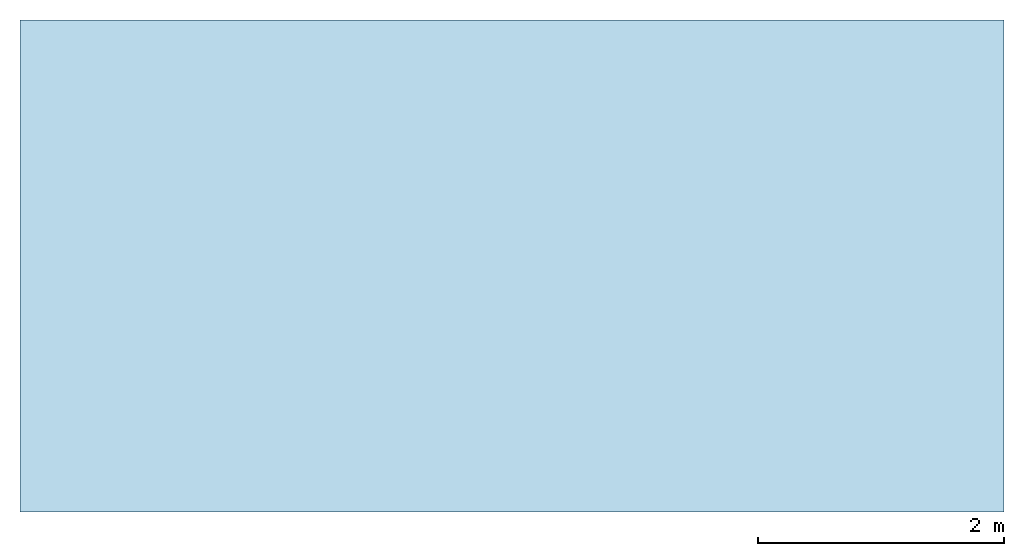
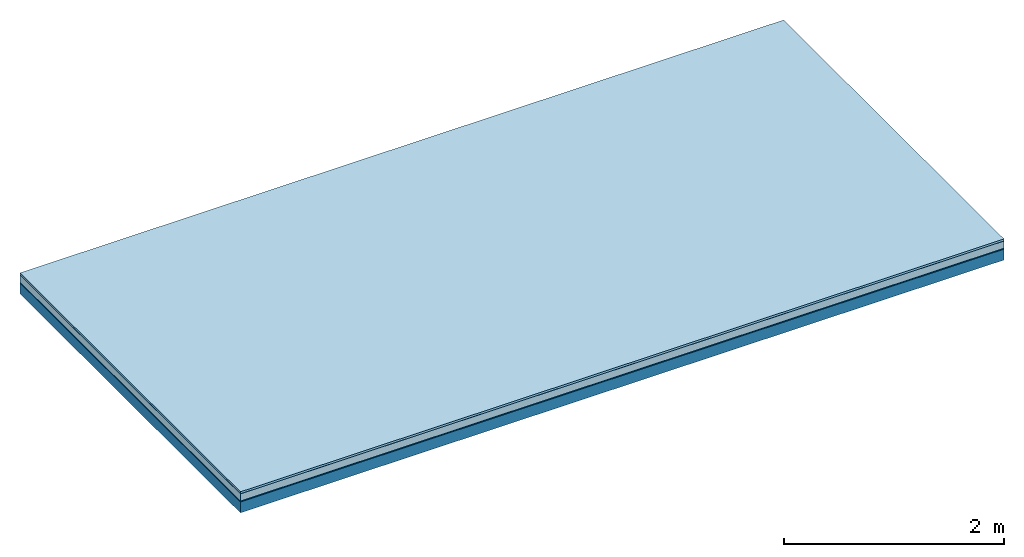
# One storey: 5 plates, 1 member, 1 element without a shape of its own.
"""IFC4 building model written with IfcOpenShell, lengths in metres."""

from ifc_helpers import new_model, si_unit, derived_unit, direction, frame, frame_2d, origin, origin_with_axes, place, context, project, spatial, rectangle, extrude, material, layer, layer_set, type_object, element, aggregate, save


model = new_model("IFC4")

# Units and contexts
plan_context = context("Plan", 3, precision=1e-05, world=origin(), true_north=direction((0.0, 1.0)))
model_context = context("Model", 3, precision=1e-05, world=origin(), true_north=direction((0.0, 1.0)))
ifc_project = project(units=[si_unit("LENGTHUNIT", "METRE"), derived_unit("SOUNDPRESSUREUNIT", [(si_unit("PRESSUREUNIT", "PASCAL", prefix="MICRO"), 0)]), si_unit("ENERGYUNIT", "JOULE", prefix="MEGA"), si_unit("MASSUNIT", "GRAM", prefix="KILO"), derived_unit("THERMALTRANSMITTANCEUNIT", [(si_unit("POWERUNIT", "WATT"), 1), (si_unit("AREAUNIT", "SQUARE_METRE"), -1), (si_unit("THERMODYNAMICTEMPERATUREUNIT", "KELVIN"), -1)]), derived_unit("AREADENSITYUNIT", [(si_unit("MASSUNIT", "GRAM", prefix="KILO"), 1), (si_unit("AREAUNIT", "SQUARE_METRE"), -1)]), derived_unit("USERDEFINED", [(si_unit("ENERGYUNIT", "JOULE", prefix="MEGA"), 1), (si_unit("AREAUNIT", "SQUARE_METRE"), -1)])], contexts=[plan_context, model_context])

# Site, building, storey
site = spatial("IfcSite", under=ifc_project)
building_placement = place(None, origin())
building = spatial("IfcBuilding", under=site, at=building_placement)
storey_placement = place(building_placement, origin())
storey = spatial("IfcBuildingStorey", under=building, at=storey_placement)

# Slab, member, plates
ifc_material_1 = material(Name="with tongue and groove", Category="07.009")
ifc_layer_1 = layer(ifc_material_1, 0.022, Name="Flooring")
ifc_material_2 = material(Category="09.006")
ifc_layer_2 = layer(ifc_material_2, 0.0005, Name="layer")
ifc_material_3 = material(Category="07.011")
ifc_layer_3 = layer(ifc_material_3, 0.08, Name="On-material")
ifc_material_4 = material(Name="Wood fiber generic product", Category="10.009")
ifc_layer_4 = layer(ifc_material_4, 0.01, Name="Impact sound insulation")
ifc_material_5 = material(Name="protection", Category="09.007")
ifc_layer_5 = layer(ifc_material_5, 0.0005, Name="Sub-floor")
ifc_material_6 = material(Name="no composite action")
ifc_layer_6 = layer(ifc_material_6, 0.0, Name="Bond")
ifc_layer_7 = layer(None, 0.12, Name="Supporting structure")
ifc_layer_set = layer_set([ifc_layer_1, ifc_layer_2, ifc_layer_3, ifc_layer_4, ifc_layer_5, ifc_layer_6, ifc_layer_7])
slab_type = type_object("IfcSlabType", Name="A2015", PredefinedType="NOTDEFINED", material=ifc_layer_set)
slab_placement = place(None, frame((0.0, 0.0, 0.0), z_axis=(0.0, 0.0, -1.0), x_axis=(1.0, 0.0, 0.0)))
slab = element("IfcSlab", 1, at=slab_placement, inside=storey, type_object=slab_type, material=ifc_layer_set, Name="Slab #1")
ifc_material_7 = material(Name="Solid timber panel")
member_placement = place(slab_placement, origin())
member = element("IfcMember", 2, at=member_placement, material=ifc_material_7, Name="Supporting structure", context=plan_context, shape_type="SweptSolid", body=[
    extrude(rectangle(XDim=1.0, YDim=0.12, at=frame_2d((0.5, 0.06), x_axis=(1.0, 0.0))), frame((0.0, 4.0, 0.113), z_axis=(0.0, -1.0, 0.0), x_axis=(1.0, 0.0, 0.0)), (0.0, 0.0, 1.0), 4.0),
    extrude(rectangle(XDim=1.0, YDim=0.12, at=frame_2d((0.5, 0.06), x_axis=(1.0, 0.0))), frame((1.0, 4.0, 0.113), z_axis=(0.0, -1.0, 0.0), x_axis=(1.0, 0.0, 0.0)), (0.0, 0.0, 1.0), 4.0),
    extrude(rectangle(XDim=1.0, YDim=0.12, at=frame_2d((0.5, 0.06), x_axis=(1.0, 0.0))), frame((2.0, 4.0, 0.113), z_axis=(0.0, -1.0, 0.0), x_axis=(1.0, 0.0, 0.0)), (0.0, 0.0, 1.0), 4.0),
    extrude(rectangle(XDim=1.0, YDim=0.12, at=frame_2d((0.5, 0.06), x_axis=(1.0, 0.0))), frame((3.0, 4.0, 0.113), z_axis=(0.0, -1.0, 0.0), x_axis=(1.0, 0.0, 0.0)), (0.0, 0.0, 1.0), 4.0),
    extrude(rectangle(XDim=1.0, YDim=0.12, at=frame_2d((0.5, 0.06), x_axis=(1.0, 0.0))), frame((4.0, 4.0, 0.113), z_axis=(0.0, -1.0, 0.0), x_axis=(1.0, 0.0, 0.0)), (0.0, 0.0, 1.0), 4.0),
    extrude(rectangle(XDim=1.0, YDim=0.12, at=frame_2d((0.5, 0.06), x_axis=(1.0, 0.0))), frame((5.0, 4.0, 0.113), z_axis=(0.0, -1.0, 0.0), x_axis=(1.0, 0.0, 0.0)), (0.0, 0.0, 1.0), 4.0),
    extrude(rectangle(XDim=1.0, YDim=0.12, at=frame_2d((0.5, 0.06), x_axis=(1.0, 0.0))), frame((6.0, 4.0, 0.113), z_axis=(0.0, -1.0, 0.0), x_axis=(1.0, 0.0, 0.0)), (0.0, 0.0, 1.0), 4.0),
    extrude(rectangle(XDim=1.0, YDim=0.12, at=frame_2d((0.5, 0.06), x_axis=(1.0, 0.0))), frame((7.0, 4.0, 0.113), z_axis=(0.0, -1.0, 0.0), x_axis=(1.0, 0.0, 0.0)), (0.0, 0.0, 1.0), 4.0),
])
plate_1_placement = place(slab_placement, origin())
plate_1 = element("IfcPlate", 3, at=plate_1_placement, material=ifc_material_1, Name="Flooring", context=plan_context, shape_type="SweptSolid", body=[
    extrude(rectangle(XDim=8.0, YDim=4.0, at=frame_2d((4.0, 2.0), x_axis=(1.0, 0.0))), origin_with_axes(), (0.0, 0.0, 1.0), 0.022),
])
plate_2_placement = place(slab_placement, origin())
plate_2 = element("IfcPlate", 4, at=plate_2_placement, material=ifc_material_2, Name="layer", context=plan_context, shape_type="SweptSolid", body=[
    extrude(rectangle(XDim=8.0, YDim=4.0, at=frame_2d((4.0, 2.0), x_axis=(1.0, 0.0))), frame((0.0, 0.0, 0.022), z_axis=(0.0, 0.0, 1.0), x_axis=(1.0, 0.0, 0.0)), (0.0, 0.0, 1.0), 0.0005),
])
plate_3_placement = place(slab_placement, origin())
plate_3 = element("IfcPlate", 5, at=plate_3_placement, material=ifc_material_3, Name="On-material", context=plan_context, shape_type="SweptSolid", body=[
    extrude(rectangle(XDim=8.0, YDim=4.0, at=frame_2d((4.0, 2.0), x_axis=(1.0, 0.0))), frame((0.0, 0.0, 0.0225), z_axis=(0.0, 0.0, 1.0), x_axis=(1.0, 0.0, 0.0)), (0.0, 0.0, 1.0), 0.08),
])
plate_4_placement = place(slab_placement, origin())
plate_4 = element("IfcPlate", 6, at=plate_4_placement, material=ifc_material_4, Name="Impact sound insulation", context=plan_context, shape_type="SweptSolid", body=[
    extrude(rectangle(XDim=8.0, YDim=4.0, at=frame_2d((4.0, 2.0), x_axis=(1.0, 0.0))), frame((0.0, 0.0, 0.1025), z_axis=(0.0, 0.0, 1.0), x_axis=(1.0, 0.0, 0.0)), (0.0, 0.0, 1.0), 0.01),
])
plate_5_placement = place(slab_placement, origin())
plate_5 = element("IfcPlate", 7, at=plate_5_placement, material=ifc_material_5, Name="Sub-floor", context=plan_context, shape_type="SweptSolid", body=[
    extrude(rectangle(XDim=8.0, YDim=4.0, at=frame_2d((4.0, 2.0), x_axis=(1.0, 0.0))), frame((0.0, 0.0, 0.1125), z_axis=(0.0, 0.0, 1.0), x_axis=(1.0, 0.0, 0.0)), (0.0, 0.0, 1.0), 0.0005),
])
aggregate(slab, [plate_1, plate_2, plate_3, plate_4, plate_5, member])

save(model, "model.ifc")
